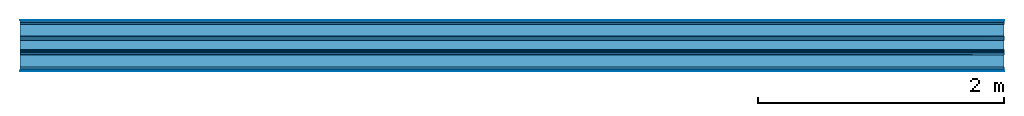
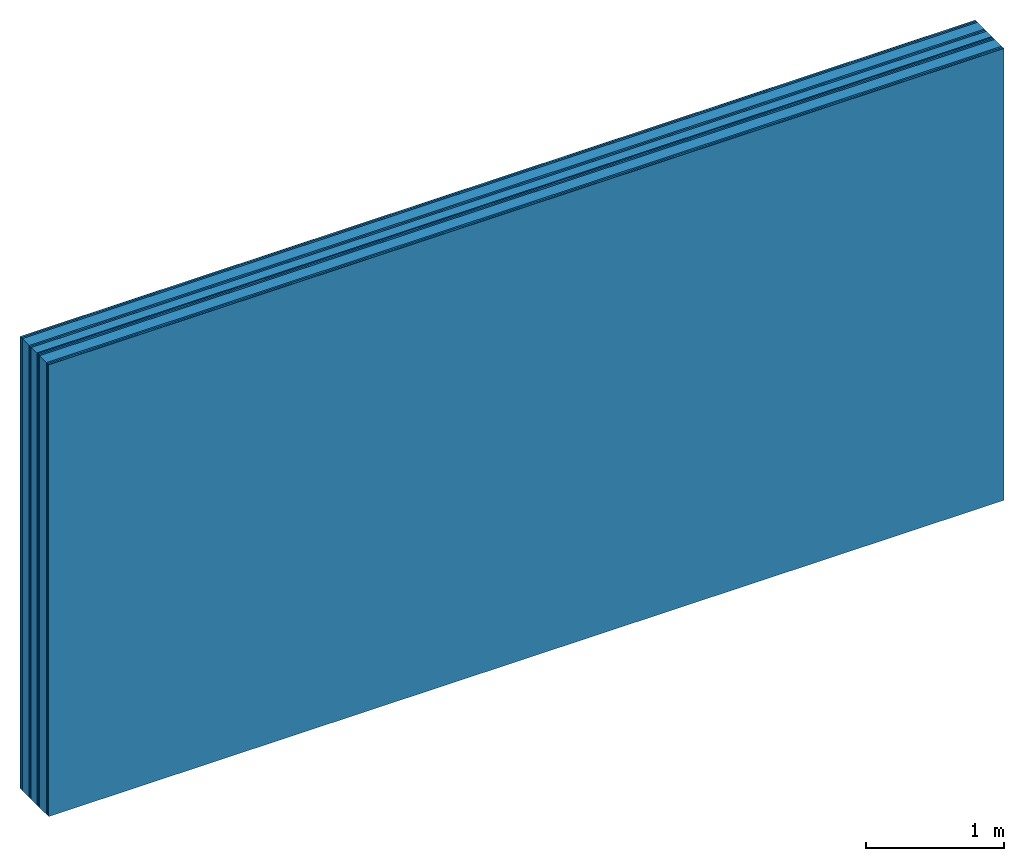
# One storey: 12 plates, 2 members, 1 element without a shape of its own.
"""IFC4 building model written with IfcOpenShell, lengths in metres."""

from ifc_helpers import new_model, si_unit, derived_unit, direction, frame, frame_2d, origin, origin_with_axes, place, context, project, spatial, rectangle, extrude, material, layer, layer_set, type_object, element, aggregate, save


model = new_model("IFC4")

# Units and contexts
plan_context = context("Plan", 3, precision=1e-05, world=origin(), true_north=direction((0.0, 1.0)))
model_context = context("Model", 3, precision=1e-05, world=origin(), true_north=direction((0.0, 1.0)))
ifc_project = project(units=[si_unit("LENGTHUNIT", "METRE"), derived_unit("SOUNDPRESSUREUNIT", [(si_unit("PRESSUREUNIT", "PASCAL", prefix="MICRO"), 0)]), si_unit("ENERGYUNIT", "JOULE", prefix="MEGA"), si_unit("MASSUNIT", "GRAM", prefix="KILO"), derived_unit("THERMALTRANSMITTANCEUNIT", [(si_unit("POWERUNIT", "WATT"), 1), (si_unit("AREAUNIT", "SQUARE_METRE"), -1), (si_unit("THERMODYNAMICTEMPERATUREUNIT", "KELVIN"), -1)]), derived_unit("AREADENSITYUNIT", [(si_unit("MASSUNIT", "GRAM", prefix="KILO"), 1), (si_unit("AREAUNIT", "SQUARE_METRE"), -1)]), derived_unit("USERDEFINED", [(si_unit("ENERGYUNIT", "JOULE", prefix="MEGA"), 1), (si_unit("AREAUNIT", "SQUARE_METRE"), -1)])], contexts=[plan_context, model_context])

# Site, building, storey
site = spatial("IfcSite", under=ifc_project)
building_placement = place(None, origin())
building = spatial("IfcBuilding", under=site, at=building_placement)
storey_placement = place(building_placement, origin())
storey = spatial("IfcBuildingStorey", under=building, at=storey_placement)

# Wall, members, plates
ifc_material_1 = material(Category="04.001")
ifc_layer_1 = layer(ifc_material_1, 0.003, Name="Surface")
ifc_material_2 = material(Name="DFH2IR Knauf Diamant hard- plasterboard", Category="03.007")
ifc_layer_2 = layer(ifc_material_2, 0.015, Name="room side 2nd layer")
ifc_layer_3 = layer(ifc_material_2, 0.015, Name="room side 1st layer")
ifc_material_3 = material(Name="of the art")
ifc_layer_4 = layer(ifc_material_3, 0.0, Name="Bond")
ifc_layer_5 = layer(None, 0.1, Name="Support")
ifc_layer_6 = layer(ifc_material_3, 0.0, Name="Bond")
ifc_layer_7 = layer(ifc_material_2, 0.015, Name="outside 1st layer")
ifc_layer_8 = layer(ifc_material_2, 0.015, Name="outside 2nd layer")
ifc_material_4 = material(Category="10.008")
ifc_layer_9 = layer(ifc_material_4, 0.08, Name="Intermediate insulation")
ifc_material_5 = material(Name="Air")
ifc_layer_10 = layer(ifc_material_5, 0.01, Name="Air gap")
ifc_layer_11 = layer(ifc_material_2, 0.015, Name="2nd layer")
ifc_layer_12 = layer(ifc_material_2, 0.015, Name="outside 1st layer")
ifc_layer_13 = layer(ifc_material_3, 0.0, Name="Bond")
ifc_layer_14 = layer(None, 0.1, Name="Support")
ifc_layer_15 = layer(ifc_material_3, 0.0, Name="Bond")
ifc_layer_16 = layer(ifc_material_2, 0.015, Name="room side 1st layer")
ifc_layer_17 = layer(ifc_material_2, 0.015, Name="room side 2nd layer")
ifc_layer_18 = layer(ifc_material_1, 0.003, Name="Surface")
ifc_layer_set = layer_set([ifc_layer_1, ifc_layer_2, ifc_layer_3, ifc_layer_4, ifc_layer_5, ifc_layer_6, ifc_layer_7, ifc_layer_8, ifc_layer_9, ifc_layer_10, ifc_layer_11, ifc_layer_12, ifc_layer_13, ifc_layer_14, ifc_layer_15, ifc_layer_16, ifc_layer_17, ifc_layer_18])
wall_type = type_object("IfcWallType", Name="B0306", PredefinedType="NOTDEFINED", material=ifc_layer_set)
wall_placement = place(None, frame((0.0, 0.0, 0.0), z_axis=(0.0, -1.0, 0.0), x_axis=(1.0, 0.0, 0.0)))
wall = element("IfcWall", 1, at=wall_placement, inside=storey, type_object=wall_type, material=ifc_layer_set, Name="Wall #1")
ifc_material_6 = material(Name="Solid timber panel")
member_1_placement = place(wall_placement, origin())
member_1 = element("IfcMember", 2, at=member_1_placement, material=ifc_material_6, Name="Support", context=plan_context, shape_type="SweptSolid", body=[
    extrude(rectangle(XDim=1.0, YDim=0.1, at=frame_2d((0.5, 0.05), x_axis=(1.0, 0.0))), frame((0.0, 4.0, 0.033), z_axis=(0.0, -1.0, 0.0), x_axis=(1.0, 0.0, 0.0)), (0.0, 0.0, 1.0), 4.0),
    extrude(rectangle(XDim=1.0, YDim=0.1, at=frame_2d((0.5, 0.05), x_axis=(1.0, 0.0))), frame((1.0, 4.0, 0.033), z_axis=(0.0, -1.0, 0.0), x_axis=(1.0, 0.0, 0.0)), (0.0, 0.0, 1.0), 4.0),
    extrude(rectangle(XDim=1.0, YDim=0.1, at=frame_2d((0.5, 0.05), x_axis=(1.0, 0.0))), frame((2.0, 4.0, 0.033), z_axis=(0.0, -1.0, 0.0), x_axis=(1.0, 0.0, 0.0)), (0.0, 0.0, 1.0), 4.0),
    extrude(rectangle(XDim=1.0, YDim=0.1, at=frame_2d((0.5, 0.05), x_axis=(1.0, 0.0))), frame((3.0, 4.0, 0.033), z_axis=(0.0, -1.0, 0.0), x_axis=(1.0, 0.0, 0.0)), (0.0, 0.0, 1.0), 4.0),
    extrude(rectangle(XDim=1.0, YDim=0.1, at=frame_2d((0.5, 0.05), x_axis=(1.0, 0.0))), frame((4.0, 4.0, 0.033), z_axis=(0.0, -1.0, 0.0), x_axis=(1.0, 0.0, 0.0)), (0.0, 0.0, 1.0), 4.0),
    extrude(rectangle(XDim=1.0, YDim=0.1, at=frame_2d((0.5, 0.05), x_axis=(1.0, 0.0))), frame((5.0, 4.0, 0.033), z_axis=(0.0, -1.0, 0.0), x_axis=(1.0, 0.0, 0.0)), (0.0, 0.0, 1.0), 4.0),
    extrude(rectangle(XDim=1.0, YDim=0.1, at=frame_2d((0.5, 0.05), x_axis=(1.0, 0.0))), frame((6.0, 4.0, 0.033), z_axis=(0.0, -1.0, 0.0), x_axis=(1.0, 0.0, 0.0)), (0.0, 0.0, 1.0), 4.0),
    extrude(rectangle(XDim=1.0, YDim=0.1, at=frame_2d((0.5, 0.05), x_axis=(1.0, 0.0))), frame((7.0, 4.0, 0.033), z_axis=(0.0, -1.0, 0.0), x_axis=(1.0, 0.0, 0.0)), (0.0, 0.0, 1.0), 4.0),
])
member_2_placement = place(wall_placement, origin())
member_2 = element("IfcMember", 3, at=member_2_placement, material=ifc_material_6, Name="Support", context=plan_context, shape_type="SweptSolid", body=[
    extrude(rectangle(XDim=1.0, YDim=0.1, at=frame_2d((0.5, 0.05), x_axis=(1.0, 0.0))), frame((0.0, 4.0, 0.283), z_axis=(0.0, -1.0, 0.0), x_axis=(1.0, 0.0, 0.0)), (0.0, 0.0, 1.0), 4.0),
    extrude(rectangle(XDim=1.0, YDim=0.1, at=frame_2d((0.5, 0.05), x_axis=(1.0, 0.0))), frame((1.0, 4.0, 0.283), z_axis=(0.0, -1.0, 0.0), x_axis=(1.0, 0.0, 0.0)), (0.0, 0.0, 1.0), 4.0),
    extrude(rectangle(XDim=1.0, YDim=0.1, at=frame_2d((0.5, 0.05), x_axis=(1.0, 0.0))), frame((2.0, 4.0, 0.283), z_axis=(0.0, -1.0, 0.0), x_axis=(1.0, 0.0, 0.0)), (0.0, 0.0, 1.0), 4.0),
    extrude(rectangle(XDim=1.0, YDim=0.1, at=frame_2d((0.5, 0.05), x_axis=(1.0, 0.0))), frame((3.0, 4.0, 0.283), z_axis=(0.0, -1.0, 0.0), x_axis=(1.0, 0.0, 0.0)), (0.0, 0.0, 1.0), 4.0),
    extrude(rectangle(XDim=1.0, YDim=0.1, at=frame_2d((0.5, 0.05), x_axis=(1.0, 0.0))), frame((4.0, 4.0, 0.283), z_axis=(0.0, -1.0, 0.0), x_axis=(1.0, 0.0, 0.0)), (0.0, 0.0, 1.0), 4.0),
    extrude(rectangle(XDim=1.0, YDim=0.1, at=frame_2d((0.5, 0.05), x_axis=(1.0, 0.0))), frame((5.0, 4.0, 0.283), z_axis=(0.0, -1.0, 0.0), x_axis=(1.0, 0.0, 0.0)), (0.0, 0.0, 1.0), 4.0),
    extrude(rectangle(XDim=1.0, YDim=0.1, at=frame_2d((0.5, 0.05), x_axis=(1.0, 0.0))), frame((6.0, 4.0, 0.283), z_axis=(0.0, -1.0, 0.0), x_axis=(1.0, 0.0, 0.0)), (0.0, 0.0, 1.0), 4.0),
    extrude(rectangle(XDim=1.0, YDim=0.1, at=frame_2d((0.5, 0.05), x_axis=(1.0, 0.0))), frame((7.0, 4.0, 0.283), z_axis=(0.0, -1.0, 0.0), x_axis=(1.0, 0.0, 0.0)), (0.0, 0.0, 1.0), 4.0),
])
plate_1_placement = place(wall_placement, origin())
plate_1 = element("IfcPlate", 4, at=plate_1_placement, material=ifc_material_1, Name="Surface", context=plan_context, shape_type="SweptSolid", body=[
    extrude(rectangle(XDim=8.0, YDim=4.0, at=frame_2d((4.0, 2.0), x_axis=(1.0, 0.0))), origin_with_axes(), (0.0, 0.0, 1.0), 0.003),
])
plate_2_placement = place(wall_placement, origin())
plate_2 = element("IfcPlate", 5, at=plate_2_placement, material=ifc_material_2, Name="room side 2nd layer", context=plan_context, shape_type="SweptSolid", body=[
    extrude(rectangle(XDim=8.0, YDim=4.0, at=frame_2d((4.0, 2.0), x_axis=(1.0, 0.0))), frame((0.0, 0.0, 0.003), z_axis=(0.0, 0.0, 1.0), x_axis=(1.0, 0.0, 0.0)), (0.0, 0.0, 1.0), 0.015),
])
plate_3_placement = place(wall_placement, origin())
plate_3 = element("IfcPlate", 6, at=plate_3_placement, material=ifc_material_2, Name="room side 1st layer", context=plan_context, shape_type="SweptSolid", body=[
    extrude(rectangle(XDim=8.0, YDim=4.0, at=frame_2d((4.0, 2.0), x_axis=(1.0, 0.0))), frame((0.0, 0.0, 0.018), z_axis=(0.0, 0.0, 1.0), x_axis=(1.0, 0.0, 0.0)), (0.0, 0.0, 1.0), 0.015),
])
plate_4_placement = place(wall_placement, origin())
plate_4 = element("IfcPlate", 7, at=plate_4_placement, material=ifc_material_2, Name="outside 1st layer", context=plan_context, shape_type="SweptSolid", body=[
    extrude(rectangle(XDim=8.0, YDim=4.0, at=frame_2d((4.0, 2.0), x_axis=(1.0, 0.0))), frame((0.0, 0.0, 0.133), z_axis=(0.0, 0.0, 1.0), x_axis=(1.0, 0.0, 0.0)), (0.0, 0.0, 1.0), 0.015),
])
plate_5_placement = place(wall_placement, origin())
plate_5 = element("IfcPlate", 8, at=plate_5_placement, material=ifc_material_2, Name="outside 2nd layer", context=plan_context, shape_type="SweptSolid", body=[
    extrude(rectangle(XDim=8.0, YDim=4.0, at=frame_2d((4.0, 2.0), x_axis=(1.0, 0.0))), frame((0.0, 0.0, 0.148), z_axis=(0.0, 0.0, 1.0), x_axis=(1.0, 0.0, 0.0)), (0.0, 0.0, 1.0), 0.015),
])
plate_6_placement = place(wall_placement, origin())
plate_6 = element("IfcPlate", 9, at=plate_6_placement, material=ifc_material_4, Name="Intermediate insulation", context=plan_context, shape_type="SweptSolid", body=[
    extrude(rectangle(XDim=8.0, YDim=4.0, at=frame_2d((4.0, 2.0), x_axis=(1.0, 0.0))), frame((0.0, 0.0, 0.163), z_axis=(0.0, 0.0, 1.0), x_axis=(1.0, 0.0, 0.0)), (0.0, 0.0, 1.0), 0.08),
])
plate_7_placement = place(wall_placement, origin())
plate_7 = element("IfcPlate", 10, at=plate_7_placement, material=ifc_material_5, Name="Air gap", context=plan_context, shape_type="SweptSolid", body=[
    extrude(rectangle(XDim=8.0, YDim=4.0, at=frame_2d((4.0, 2.0), x_axis=(1.0, 0.0))), frame((0.0, 0.0, 0.243), z_axis=(0.0, 0.0, 1.0), x_axis=(1.0, 0.0, 0.0)), (0.0, 0.0, 1.0), 0.01),
])
plate_8_placement = place(wall_placement, origin())
plate_8 = element("IfcPlate", 11, at=plate_8_placement, material=ifc_material_2, Name="2nd layer", context=plan_context, shape_type="SweptSolid", body=[
    extrude(rectangle(XDim=8.0, YDim=4.0, at=frame_2d((4.0, 2.0), x_axis=(1.0, 0.0))), frame((0.0, 0.0, 0.253), z_axis=(0.0, 0.0, 1.0), x_axis=(1.0, 0.0, 0.0)), (0.0, 0.0, 1.0), 0.015),
])
plate_9_placement = place(wall_placement, origin())
plate_9 = element("IfcPlate", 12, at=plate_9_placement, material=ifc_material_2, Name="outside 1st layer", context=plan_context, shape_type="SweptSolid", body=[
    extrude(rectangle(XDim=8.0, YDim=4.0, at=frame_2d((4.0, 2.0), x_axis=(1.0, 0.0))), frame((0.0, 0.0, 0.268), z_axis=(0.0, 0.0, 1.0), x_axis=(1.0, 0.0, 0.0)), (0.0, 0.0, 1.0), 0.015),
])
plate_10_placement = place(wall_placement, origin())
plate_10 = element("IfcPlate", 13, at=plate_10_placement, material=ifc_material_2, Name="room side 1st layer", context=plan_context, shape_type="SweptSolid", body=[
    extrude(rectangle(XDim=8.0, YDim=4.0, at=frame_2d((4.0, 2.0), x_axis=(1.0, 0.0))), frame((0.0, 0.0, 0.383), z_axis=(0.0, 0.0, 1.0), x_axis=(1.0, 0.0, 0.0)), (0.0, 0.0, 1.0), 0.015),
])
plate_11_placement = place(wall_placement, origin())
plate_11 = element("IfcPlate", 14, at=plate_11_placement, material=ifc_material_2, Name="room side 2nd layer", context=plan_context, shape_type="SweptSolid", body=[
    extrude(rectangle(XDim=8.0, YDim=4.0, at=frame_2d((4.0, 2.0), x_axis=(1.0, 0.0))), frame((0.0, 0.0, 0.398), z_axis=(0.0, 0.0, 1.0), x_axis=(1.0, 0.0, 0.0)), (0.0, 0.0, 1.0), 0.015),
])
plate_12_placement = place(wall_placement, origin())
plate_12 = element("IfcPlate", 15, at=plate_12_placement, material=ifc_material_1, Name="Surface", context=plan_context, shape_type="SweptSolid", body=[
    extrude(rectangle(XDim=8.0, YDim=4.0, at=frame_2d((4.0, 2.0), x_axis=(1.0, 0.0))), frame((0.0, 0.0, 0.413), z_axis=(0.0, 0.0, 1.0), x_axis=(1.0, 0.0, 0.0)), (0.0, 0.0, 1.0), 0.003),
])
aggregate(wall, [plate_1, plate_2, plate_3, member_1, plate_4, plate_5, plate_6, plate_7, plate_8, plate_9, member_2, plate_10, plate_11, plate_12])

save(model, "model.ifc")
